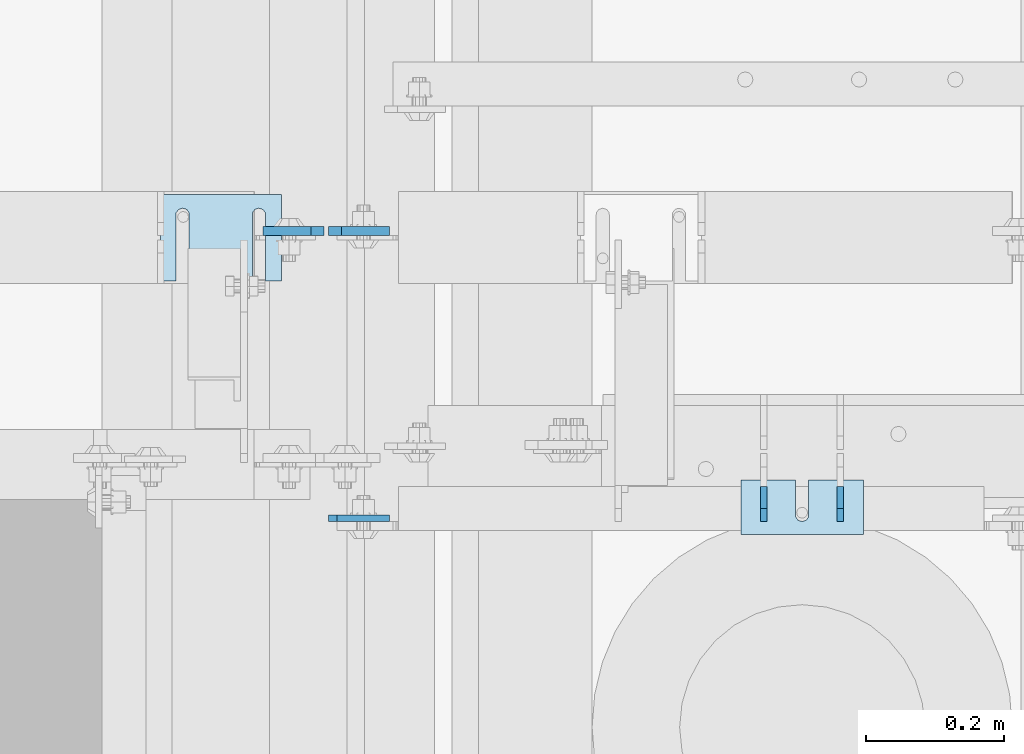
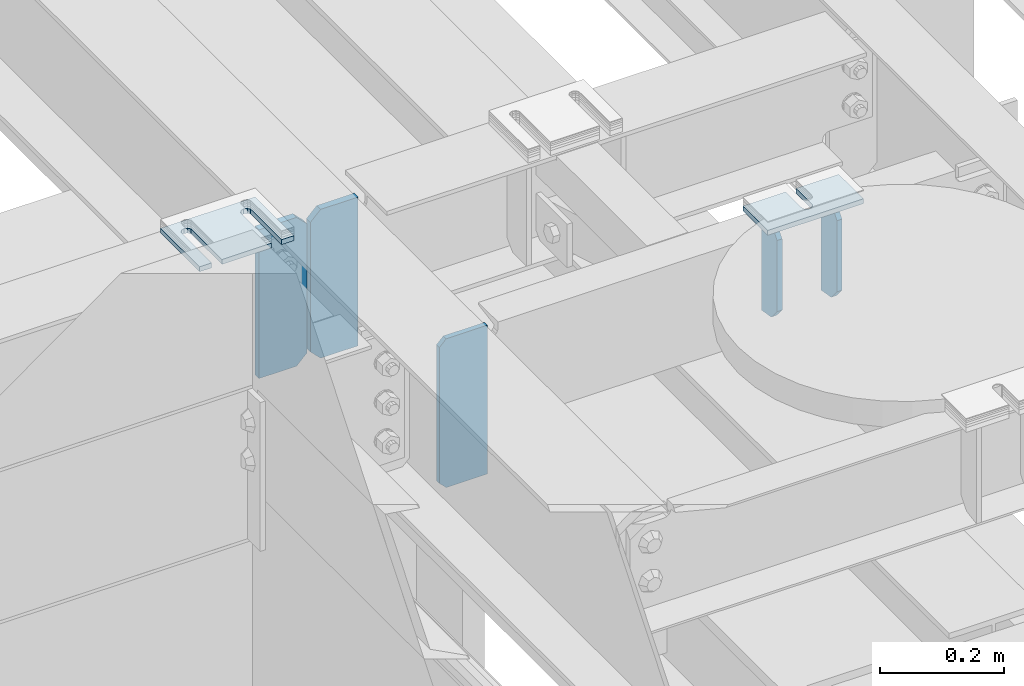
# One storey, part 1612 of 1876: 7 plates, 4 elements without a shape of their own.
"""IFC2X3 building model written with IfcOpenShell, lengths in millimetres."""

from ifc_helpers import new_model, si_unit, frame, origin_with_axes, place, context, subcontext, project, spatial, faceted_brep, material, type_object, element, aggregate, save


model = new_model("IFC2X3")

# Units and contexts
model_context = context("Model", 3, precision=1e-05, world=origin_with_axes())
body_context = subcontext(model_context, "Body", "Model", "MODEL_VIEW")
ifc_project = project(units=[si_unit("LENGTHUNIT", "METRE", prefix="MILLI"), si_unit("AREAUNIT", "SQUARE_METRE"), si_unit("VOLUMEUNIT", "CUBIC_METRE"), si_unit("MASSUNIT", "GRAM", prefix="KILO"), si_unit("TIMEUNIT", "SECOND"), si_unit("PLANEANGLEUNIT", "RADIAN"), si_unit("SOLIDANGLEUNIT", "STERADIAN"), si_unit("THERMODYNAMICTEMPERATUREUNIT", "DEGREE_CELSIUS"), si_unit("LUMINOUSINTENSITYUNIT", "LUMEN")], contexts=[model_context])

# Site, building, storey
site_placement = place(None, origin_with_axes())
site = spatial("IfcSite", under=ifc_project, at=site_placement, CompositionType="ELEMENT")
building_placement = place(site_placement, origin_with_axes())
building = spatial("IfcBuilding", under=site, at=building_placement, Name="Undefined", CompositionType="ELEMENT")
storey_placement = place(building_placement, origin_with_axes())
storey = spatial("IfcBuildingStorey", under=building, at=storey_placement, Name="Undefined", CompositionType="ELEMENT", Elevation=0.0)

# Assembly, plates
assembly_1_placement = place(storey_placement, origin_with_axes())
assembly_1 = element("IfcElementAssembly", 1, at=assembly_1_placement, inside=storey, Name="BEAM", AssemblyPlace="NOTDEFINED", PredefinedType="RIGID_FRAME")
ifc_material = material(Name="STEEL/A36")
plate_type_1 = type_object("IfcPlateType", PredefinedType="NOTDEFINED")
plate_1_placement = place(assembly_1_placement, frame((1801.8125, 3122.61299991608, 17681.575), z_axis=(0.0, 0.0, 1.0), x_axis=(1.0, 0.0, 0.0)))
plate_1 = element("IfcPlate", 2, at=plate_1_placement, type_object=plate_type_1, material=ifc_material, Name="PLATE", context=body_context, shape_type="Brep", body=[
    faceted_brep([(3.7040990719106e-08, -4.76249999999982, 12.6999998092651), (0.0, -4.76249999999982, 279.40000629425), (0.0, 4.76249999999982, 279.40000629425), (3.70396264770534e-08, 4.76249999999982, 12.6999998092651), (12.6999998092651, -4.76249999999982, 292.100006103516), (12.6999998092651, 4.76249999999982, 292.100006103516), (88.9000015258789, -4.76249999999982, 292.100006103516), (88.9000015258789, 4.76249999999982, 292.100006103516), (88.9000015258789, -4.76249999999982, 0.0), (88.9000015258789, 4.76249999999982, 0.0), (12.699999809267, -4.76249999999754, 1.09139364212751e-11), (12.6999998092651, 4.76250000000255, 1.09139364212751e-11)], [[[0, 1, 2, 3]], [[1, 4, 5, 2]], [[4, 6, 7, 5]], [[6, 8, 9, 7]], [[8, 10, 11, 9]], [[10, 0, 3, 11]], [[5, 7, 9, 11, 3, 2]], [[10, 8, 6, 4, 1, 0]]]),
])
plate_type_2 = type_object("IfcPlateType", PredefinedType="NOTDEFINED")
plate_2_placement = place(assembly_1_placement, frame((1795.4625, 3539.32356576919, 17681.575), z_axis=(0.0, 0.0, 1.0), x_axis=(-1.0, 0.0, 0.0)))
plate_2 = element("IfcPlate", 3, at=plate_2_placement, type_object=plate_type_2, material=ifc_material, Name="PLATE", context=body_context, shape_type="Brep", body=[
    faceted_brep([(0.0, -6.35000000000196, 19.0499992370605), (9.09494701772928e-13, -6.34999999999832, 273.050006866455), (-2.72848410531878e-12, 6.34999999999923, 273.050006866455), (0.0, 6.35000000000105, 19.0499992370605), (19.0499992370578, -6.35000000000696, 292.100006103516), (19.049999237056, 6.3499999999915, 292.100006103516), (88.9000015258789, -6.35000000000036, 292.100006103516), (88.9000015258789, 6.35000000000036, 292.100006103516), (88.9000015258789, -6.34999999999991, 0.0), (88.9000015258789, 6.34999999999991, 0.0), (19.0499992370642, -6.35000000000105, 0.0), (19.0499992370633, 6.35000000000105, 0.0)], [[[0, 1, 2, 3]], [[1, 4, 5, 2]], [[4, 6, 7, 5]], [[6, 8, 9, 7]], [[8, 10, 11, 9]], [[10, 0, 3, 11]], [[5, 7, 9, 11, 3, 2]], [[10, 8, 6, 4, 1, 0]]]),
])
plate_3_placement = place(assembly_1_placement, frame((1801.8125, 3539.32356576919, 17681.575), z_axis=(0.0, 0.0, 1.0), x_axis=(1.0, 0.0, 0.0)))
plate_3 = element("IfcPlate", 4, at=plate_3_placement, type_object=plate_type_2, material=ifc_material, Name="PLATE", context=body_context, shape_type="Brep", body=[
    faceted_brep([(0.0, -6.35000000000196, 19.0499992370605), (9.09494701772928e-13, -6.34999999999832, 273.050006866455), (-2.72848410531878e-12, 6.34999999999923, 273.050006866455), (0.0, 6.35000000000105, 19.0499992370605), (19.0499992370578, -6.35000000000696, 292.100006103516), (19.049999237056, 6.3499999999915, 292.100006103516), (88.9000015258789, -6.35000000000036, 292.100006103516), (88.9000015258789, 6.35000000000036, 292.100006103516), (88.9000015258789, -6.34999999999991, 0.0), (88.9000015258789, 6.34999999999991, 0.0), (19.0499992370642, -6.35000000000105, 0.0), (19.0499992370633, 6.35000000000105, 0.0)], [[[0, 1, 2, 3]], [[1, 4, 5, 2]], [[4, 6, 7, 5]], [[6, 8, 9, 7]], [[8, 10, 11, 9]], [[10, 0, 3, 11]], [[5, 7, 9, 11, 3, 2]], [[10, 8, 6, 4, 1, 0]]]),
])
aggregate(assembly_1, [plate_1, plate_2, plate_3])

# Assembly, plate
assembly_2_placement = place(storey_placement, origin_with_axes())
assembly_2 = element("IfcElementAssembly", 5, at=assembly_2_placement, inside=storey, Name="SHIM PLATE", AssemblyPlace="NOTDEFINED", PredefinedType="RIGID_FRAME")
plate_type_3 = type_object("IfcPlateType", PredefinedType="NOTDEFINED")
plate_4_placement = place(assembly_2_placement, frame((2578.11073971348, 3098.8, 17987.9625), z_axis=(0.0, 1.0, 0.0), x_axis=(-1.0, 0.0, 0.0)))
plate_4 = element("IfcPlate", 6, at=plate_4_placement, type_object=plate_type_3, material=ifc_material, Name="SHIM PLATE", context=body_context, shape_type="Brep", body=[
    faceted_brep([(79.383495528351, -4.76250000000073, 79.3780288696357), (79.3844214322648, -4.76250000000073, 31.7467767062135), (79.3844214322648, 4.76250000000073, 31.7467767062135), (79.383495528351, 4.76250000000073, 79.3780288696357), (79.5371482496867, -4.76250000000073, 25.7122407615266), (79.5371482496867, 4.76250000000073, 25.7122407615266), (83.1590254736952, -4.76250000000073, 20.8830633033372), (83.1590254736952, 4.76250000000073, 20.8830633033372), (88.909413614851, -4.76250000000073, 19.0467665477618), (88.909413614851, 4.76250000000073, 19.0467665477618), (94.6598039068872, -4.76250000000073, 20.8830565678104), (94.6598039068872, 4.76250000000073, 20.8830565678104), (98.2816867873894, -4.76250000000073, 25.7122297836318), (98.2816867873894, 4.76250000000073, 25.7122297836318), (98.4344206731635, -4.76250000000073, 31.7467655494229), (98.4344206731635, 4.76250000000073, 31.7467655494229), (98.433494769024, -4.76250000000073, 79.3780288696371), (98.433494769024, 4.76250000000073, 79.3780288696371), (0.0, -4.76249999999982, 0.0), (2.0060193946847e-05, -4.76250000000073, 79.3780288696289), (2.0060193946847e-05, 4.76250000000073, 79.3780288696289), (0.0, 4.76249999999982, 0.0), (177.799530029297, -4.76250000000073, -1.77351466845721e-11), (177.799530029297, 4.76250000000073, -1.77351466845721e-11), (177.799545288079, -4.76250000000073, 79.3780288696435), (177.799545288079, 4.76250000000073, 79.3780288696435)], [[[0, 1, 2, 3]], [[4, 5, 2, 1]], [[6, 7, 5, 4]], [[8, 9, 7, 6]], [[10, 11, 9, 8]], [[12, 13, 11, 10]], [[14, 15, 13, 12]], [[16, 17, 15, 14]], [[18, 19, 20, 21]], [[22, 18, 21, 23]], [[24, 22, 23, 25]], [[12, 10, 8, 6, 4, 1, 0, 19, 18, 22, 24, 16, 14]], [[20, 19, 0, 3]], [[25, 23, 21, 20, 3, 2, 5, 7, 9, 11, 13, 15, 17]], [[24, 25, 17, 16]]]),
])
aggregate(assembly_2, [plate_4])

assembly_3_placement = place(storey_placement, origin_with_axes())
assembly_3 = element("IfcElementAssembly", 7, at=assembly_3_placement, inside=storey, Name="SHIM PLATE", AssemblyPlace="NOTDEFINED", PredefinedType="RIGID_FRAME")
plate_type_4 = type_object("IfcPlateType", PredefinedType="NOTDEFINED")
plate_5_placement = place(assembly_3_placement, frame((1733.54893551387, 3592.49779911322, 17987.9625), z_axis=(0.0, -1.0, 0.0), x_axis=(-1.0, 0.0, 0.0)))
plate_5 = element("IfcPlate", 8, at=plate_5_placement, type_object=plate_type_4, material=ifc_material, Name="SHIM PLATE", context=body_context, shape_type="Brep", body=[
    faceted_brep([(133.797984932592, -4.76250000000073, 125.39846801759), (133.799788185712, -4.76250000000073, 32.6385373098888), (133.799788185712, 4.76250000000073, 32.6385373098888), (133.797984932592, 4.76250000000073, 125.39846801759), (133.95251601168, -4.76250000000073, 26.6039999741197), (133.95251601168, 4.76250000000073, 26.6039999741197), (137.574395327988, -4.76250000000073, 21.7748223149583), (137.574395327988, 4.76250000000073, 21.7748223149583), (143.324785467194, -4.76250000000073, 19.9385271609622), (143.324785467194, 4.76250000000073, 19.9385271609622), (149.075176282759, -4.76250000000073, 21.7748201969102), (149.075176282759, 4.76250000000073, 21.7748201969102), (152.697057377795, -4.76250000000073, 26.6039965220207), (152.697057377795, 4.76250000000073, 26.6039965220207), (152.84978742646, -4.76250000000073, 32.6385338015343), (152.84978742646, 4.76250000000073, 32.6385338015343), (152.847984173361, -4.76250000000073, 125.398468017593), (152.847984173361, 4.76250000000073, 125.398468017593), (42.2236708188493, -4.76250000000073, 125.398468017582), (42.2236708188493, 4.76250000000073, 125.398468017582), (42.2254740719682, 4.76250000000073, 32.6385328059155), (42.2254740719682, -4.76250000000073, 32.6385328059155), (42.0727440233031, 4.76250000000073, 26.6039955264014), (42.0727440233031, -4.76250000000073, 26.6039955264014), (38.4508629282668, 4.76250000000073, 21.7748192012914), (38.4508629282668, -4.76250000000073, 21.7748192012914), (32.7004721127014, 4.76250000000073, 19.9385261653433), (32.7004721127014, -4.76250000000073, 19.9385261653433), (26.9500819734958, 4.76250000000073, 21.7748213193395), (26.9500819734958, -4.76250000000073, 21.7748213193395), (23.3282026571874, 4.76250000000073, 26.6039989785008), (23.3282026571874, -4.76250000000073, 26.6039989785008), (23.1754748312196, 4.76250000000073, 32.6385363142699), (23.1754748312196, -4.76250000000073, 32.6385363142699), (23.1736715780803, -4.76250000000073, 125.39846801758), (23.1736715780803, 4.76250000000073, 125.39846801758), (1.96497371689475e-05, 4.76250000000073, 125.398468017578), (1.96497371689475e-05, -4.76250000000073, 125.398468017578), (0.0, -4.76249999999982, 0.0), (0.0, 4.76249999999982, 0.0), (175.397720336914, -4.76250000000073, 7.27595761418343e-12), (175.397720336914, 4.76250000000073, 7.27595761418343e-12), (175.397735595691, -4.76250000000073, 125.398468017594), (175.397735595691, 4.76250000000073, 125.398468017594)], [[[0, 1, 2, 3]], [[4, 5, 2, 1]], [[6, 7, 5, 4]], [[8, 9, 7, 6]], [[10, 11, 9, 8]], [[12, 13, 11, 10]], [[14, 15, 13, 12]], [[16, 17, 15, 14]], [[18, 19, 20, 21]], [[21, 20, 22, 23]], [[23, 22, 24, 25]], [[25, 24, 26, 27]], [[27, 26, 28, 29]], [[29, 28, 30, 31]], [[31, 30, 32, 33]], [[34, 33, 32, 35]], [[36, 37, 34, 35]], [[38, 37, 36, 39]], [[40, 38, 39, 41]], [[42, 40, 41, 43]], [[12, 10, 8, 6, 4, 1, 0, 18, 21, 23, 25, 27, 29, 31, 33, 34, 37, 38, 40, 42, 16, 14]], [[19, 18, 0, 3]], [[43, 41, 39, 36, 35, 32, 30, 28, 26, 24, 22, 20, 19, 3, 2, 5, 7, 9, 11, 13, 15, 17]], [[42, 43, 17, 16]]]),
])
aggregate(assembly_3, [plate_5])

# Assembly, plates
assembly_4_placement = place(storey_placement, origin_with_axes())
assembly_4 = element("IfcElementAssembly", 9, at=assembly_4_placement, inside=storey, Name="BEAM", AssemblyPlace="NOTDEFINED", PredefinedType="RIGID_FRAME")
plate_type_5 = type_object("IfcPlateType", PredefinedType="NOTDEFINED")
plate_6_placement = place(assembly_4_placement, frame((2433.6375, 3168.65, 17978.9643200282), z_axis=(0.0, 0.164348990067108, -0.986402255402897), x_axis=(0.0, -0.986402255402897, -0.164348990067107)))
plate_6 = element("IfcPlate", 10, at=plate_6_placement, type_object=plate_type_5, material=ifc_material, Name="PLATE", context=body_context, shape_type="Brep", body=[
    faceted_brep([(0.0, -4.76249999999982, 0.0), (32.0008087158794, -4.76249999999982, 192.081680297815), (32.0008087158794, 4.76249999999982, 192.081680297815), (0.0, 4.76249999999982, 0.0), (62.6982748962027, -4.76249999999982, 181.561281061485), (62.6982748962027, 4.76249999999982, 181.561281061485), (77.5887637589458, -4.76249999999982, 156.594231983478), (77.5887637589458, 4.76249999999982, 156.594231983478), (54.6307491805464, -4.76249999999982, 18.791006663906), (54.6307491805464, 4.76249999999982, 18.791006663906), (32.4501686096137, -4.76249999999982, -1.63709046319127e-11), (32.4501686096137, 4.76249999999982, -1.63709046319127e-11)], [[[0, 1, 2, 3]], [[1, 4, 5, 2]], [[4, 6, 7, 5]], [[6, 8, 9, 7]], [[8, 10, 11, 9]], [[10, 0, 3, 11]], [[5, 7, 9, 11, 3, 2]], [[10, 8, 6, 4, 1, 0]]]),
])
plate_7_placement = place(assembly_4_placement, frame((2544.7625, 3168.65, 17978.9644001179), z_axis=(0.0, 0.164348990067108, -0.986402255402897), x_axis=(0.0, -0.986402255402897, -0.164348990067107)))
plate_7 = element("IfcPlate", 11, at=plate_7_placement, type_object=plate_type_5, material=ifc_material, Name="PLATE", context=body_context, shape_type="Brep", body=[
    faceted_brep([(0.0, -4.76249999999982, 0.0), (32.0008087158794, -4.76249999999982, 192.081680297815), (32.0008087158794, 4.76249999999982, 192.081680297815), (0.0, 4.76249999999982, 0.0), (62.6982748962027, -4.76249999999982, 181.561281061485), (62.6982748962027, 4.76249999999982, 181.561281061485), (77.5887637589458, -4.76249999999982, 156.594231983478), (77.5887637589458, 4.76249999999982, 156.594231983478), (54.6307491805464, -4.76249999999982, 18.791006663906), (54.6307491805464, 4.76249999999982, 18.791006663906), (32.4501686096137, -4.76249999999982, -1.63709046319127e-11), (32.4501686096137, 4.76249999999982, -1.63709046319127e-11)], [[[0, 1, 2, 3]], [[1, 4, 5, 2]], [[4, 6, 7, 5]], [[6, 8, 9, 7]], [[8, 10, 11, 9]], [[10, 0, 3, 11]], [[5, 7, 9, 11, 3, 2]], [[10, 8, 6, 4, 1, 0]]]),
])
aggregate(assembly_4, [plate_6, plate_7])

save(model, "model.ifc")
